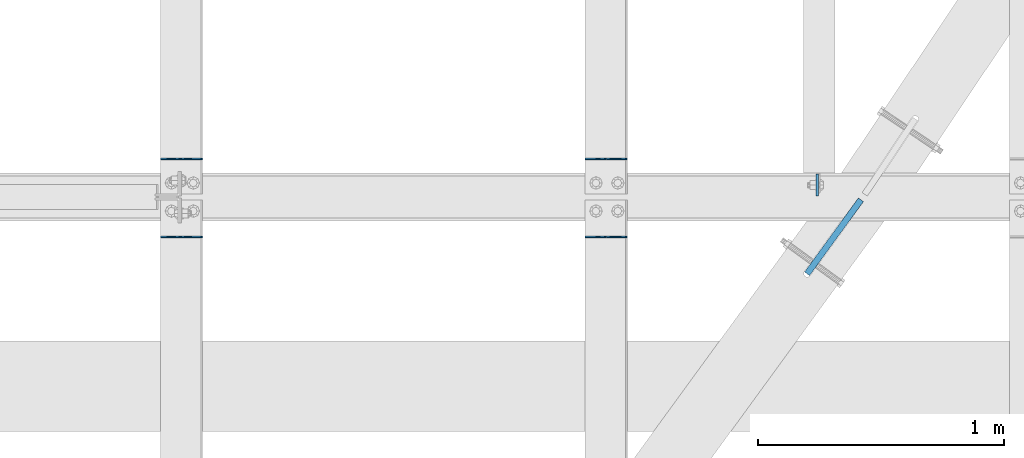
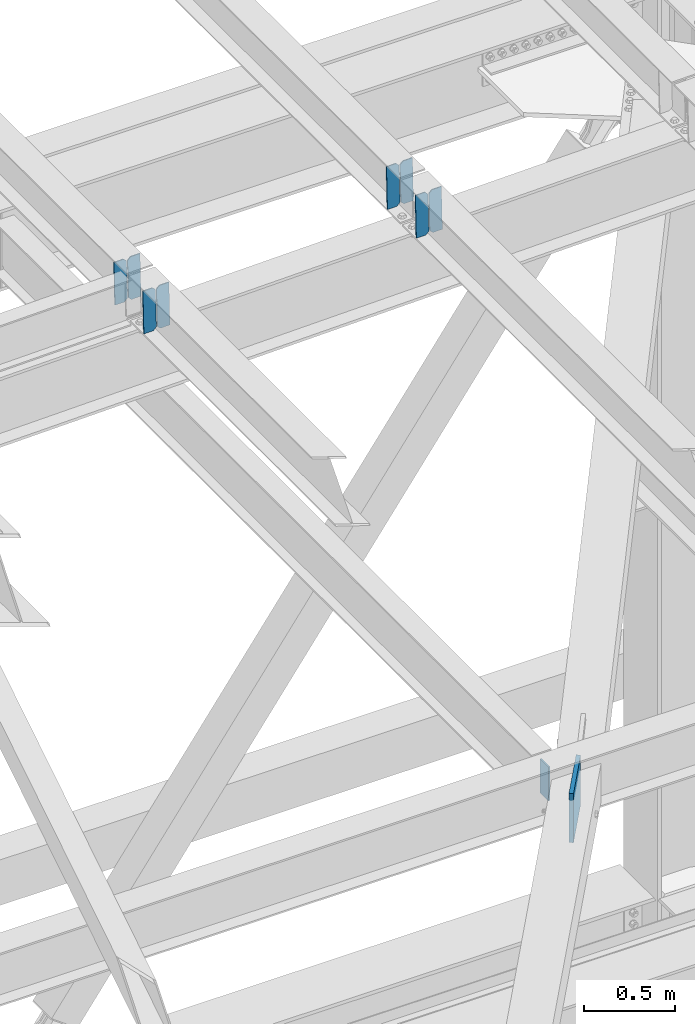
# One storey, part 3636 of 3843: 10 plates, 5 elements without a shape of their own.
"""IFC2X3 building model written with IfcOpenShell, lengths in millimetres."""

from ifc_helpers import new_model, si_unit, frame, origin_with_axes, place, context, subcontext, project, spatial, faceted_brep, material, type_object, element, aggregate, save


model = new_model("IFC2X3")

# Units and contexts
model_context = context("Model", 3, precision=1e-05, world=origin_with_axes())
body_context = subcontext(model_context, "Body", "Model", "MODEL_VIEW")
ifc_project = project(units=[si_unit("LENGTHUNIT", "METRE", prefix="MILLI"), si_unit("AREAUNIT", "SQUARE_METRE"), si_unit("VOLUMEUNIT", "CUBIC_METRE"), si_unit("MASSUNIT", "GRAM", prefix="KILO"), si_unit("TIMEUNIT", "SECOND"), si_unit("PLANEANGLEUNIT", "RADIAN"), si_unit("SOLIDANGLEUNIT", "STERADIAN"), si_unit("THERMODYNAMICTEMPERATUREUNIT", "DEGREE_CELSIUS"), si_unit("LUMINOUSINTENSITYUNIT", "LUMEN")], contexts=[model_context])

# Site, building, storey
site_placement = place(None, origin_with_axes())
site = spatial("IfcSite", under=ifc_project, at=site_placement, CompositionType="ELEMENT")
building_placement = place(site_placement, origin_with_axes())
building = spatial("IfcBuilding", under=site, at=building_placement, Name="Undefined", CompositionType="ELEMENT")
storey_placement = place(building_placement, origin_with_axes())
storey = spatial("IfcBuildingStorey", under=building, at=storey_placement, Name="Undefined", CompositionType="ELEMENT", Elevation=0.0)

# Assembly, plate
assembly_1_placement = place(storey_placement, origin_with_axes())
assembly_1 = element("IfcElementAssembly", 1, at=assembly_1_placement, inside=storey, Name="BEAM", AssemblyPlace="NOTDEFINED", PredefinedType="RIGID_FRAME")
ifc_material = material(Name="STEEL/A572-50")
plate_type_1 = type_object("IfcPlateType", PredefinedType="NOTDEFINED")
plate_1_placement = place(assembly_1_placement, frame((81322.8625, 98390.86875, 42384.6625), z_axis=(0.0, 1.0, 0.0), x_axis=(0.0, 0.0, -1.0)))
plate_1 = element("IfcPlate", 2, at=plate_1_placement, type_object=plate_type_1, material=ifc_material, Name="PLATE", context=body_context, shape_type="Brep", body=[
    faceted_brep([(0.0, -4.76249999999709, 0.0), (0.0, -4.76249999999709, 88.9000015258789), (0.0, 4.76249999999709, 88.9000015258789), (0.0, 4.76249999999709, 0.0), (228.600006102781, -4.7625000004191, 88.9000015257589), (228.600006102781, 4.76249999954598, 88.9000015257443), (228.600006103079, -4.7625000004482, 7.27595761418343e-12), (228.600006103079, 4.76249999954598, -7.27595761418343e-12)], [[[0, 1, 2, 3]], [[1, 4, 5, 2]], [[4, 6, 7, 5]], [[6, 0, 3, 7]], [[5, 7, 3, 2]], [[6, 4, 1, 0]]]),
])

# Assembly, plates
assembly_2_placement = place(storey_placement, origin_with_axes())
assembly_2 = element("IfcElementAssembly", 3, at=assembly_2_placement, inside=storey, Name="BEAM", AssemblyPlace="NOTDEFINED", PredefinedType="RIGID_FRAME")
plate_type_2 = type_object("IfcPlateType", PredefinedType="NOTDEFINED")
plate_2_placement = place(assembly_2_placement, frame((80549.4964784351, 98542.475, 46359.8298575528), z_axis=(-0.0211520980073474, 0.0, 0.999776269347241), x_axis=(-0.999776270257024, 0.0, -0.0211520550054595)))
plate_2 = element("IfcPlate", 4, at=plate_2_placement, type_object=plate_type_2, material=ifc_material, Name="PLATE", context=body_context, shape_type="Brep", body=[
    faceted_brep([(0.0, -3.17499999999927, 0.0), (6.83940015733242e-10, -3.17499999996653, 288.924999998613), (6.54836185276508e-10, 3.17500000001746, 288.924999998591), (0.0, 3.17499999999927, 0.0), (60.3250007643655, -3.17500000017753, 288.924999998606), (60.3250007643219, 3.17499999979918, 288.924999998584), (79.3750000013097, -3.17500000025029, 269.875000761494), (79.375000001266, 3.17499999972642, 269.875000761487), (79.375000000713, -3.17500000026484, 19.0499992370605), (79.3750000006985, 3.17499999971187, 19.0499992370533), (60.325000763667, -3.17500000020664, -1.45519152283669e-11), (60.3250007636234, 3.17499999977736, -3.63797880709171e-11)], [[[0, 1, 2, 3]], [[1, 4, 5, 2]], [[4, 6, 7, 5]], [[6, 8, 9, 7]], [[8, 10, 11, 9]], [[10, 0, 3, 11]], [[5, 7, 9, 11, 3, 2]], [[10, 8, 6, 4, 1, 0]]]),
])
plate_3_placement = place(assembly_2_placement, frame((80463.7906577448, 98542.475, 46358.016593951), z_axis=(-0.0211520980073474, 0.0, 0.999776269347241), x_axis=(-0.999776270257024, 0.0, -0.0211520550054595)))
plate_3 = element("IfcPlate", 5, at=plate_3_placement, type_object=plate_type_2, material=ifc_material, Name="PLATE", context=body_context, shape_type="Brep", body=[
    faceted_brep([(4.36557456851006e-11, -3.17499999998836, 19.0499992370969), (6.11180439591408e-10, -3.17499999996653, 269.875000761516), (5.96628524363041e-10, 3.17500000001746, 269.875000761502), (1.45519152283669e-11, 3.17499999998836, 19.0499992370824), (19.0499992376572, -3.17500000003201, 288.924999998606), (19.0499992376281, 3.1749999999447, 288.924999998584), (79.3750000013242, -3.17500000025029, 288.924999998591), (79.3750000013097, 3.1749999997337, 288.92499999857), (79.3750000006548, -3.17500000026484, -2.18278728425503e-11), (79.3750000006403, 3.17499999969732, -2.91038304567337e-11), (19.0499992370023, -3.17500000005384, 0.0), (19.0499992369587, 3.17499999992287, -1.45519152283669e-11)], [[[0, 1, 2, 3]], [[1, 4, 5, 2]], [[4, 6, 7, 5]], [[6, 8, 9, 7]], [[8, 10, 11, 9]], [[10, 0, 3, 11]], [[5, 7, 9, 11, 3, 2]], [[10, 8, 6, 4, 1, 0]]]),
])
aggregate(assembly_2, [plate_2, plate_3])

assembly_3_placement = place(storey_placement, origin_with_axes())
assembly_3 = element("IfcElementAssembly", 6, at=assembly_3_placement, inside=storey, Name="BEAM", AssemblyPlace="NOTDEFINED", PredefinedType="RIGID_FRAME")
plate_4_placement = place(assembly_3_placement, frame((80549.4964784317, 98224.975, 46359.8298575521), z_axis=(-0.0211520980073474, 0.0, 0.999776269347241), x_axis=(-0.999776270257024, 0.0, -0.0211520550054595)))
plate_4 = element("IfcPlate", 7, at=plate_4_placement, type_object=plate_type_2, material=ifc_material, Name="PLATE", context=body_context, shape_type="Brep", body=[
    faceted_brep([(0.0, -3.17499999999927, 0.0), (6.83940015733242e-10, -3.17499999996653, 288.924999998613), (6.54836185276508e-10, 3.17500000001746, 288.924999998591), (0.0, 3.17499999999927, 0.0), (60.3250007643655, -3.17500000017753, 288.924999998606), (60.3250007643219, 3.17499999979918, 288.924999998584), (79.3750000013097, -3.17500000025029, 269.875000761494), (79.375000001266, 3.17499999972642, 269.875000761487), (79.375000000713, -3.17500000026484, 19.0499992370605), (79.3750000006985, 3.17499999971187, 19.0499992370533), (60.325000763667, -3.17500000020664, -1.45519152283669e-11), (60.3250007636234, 3.17499999977736, -3.63797880709171e-11)], [[[0, 1, 2, 3]], [[1, 4, 5, 2]], [[4, 6, 7, 5]], [[6, 8, 9, 7]], [[8, 10, 11, 9]], [[10, 0, 3, 11]], [[5, 7, 9, 11, 3, 2]], [[10, 8, 6, 4, 1, 0]]]),
])
plate_5_placement = place(assembly_3_placement, frame((80463.7906577414, 98224.975, 46358.0165939504), z_axis=(-0.0211520980073474, 0.0, 0.999776269347241), x_axis=(-0.999776270257024, 0.0, -0.0211520550054595)))
plate_5 = element("IfcPlate", 8, at=plate_5_placement, type_object=plate_type_2, material=ifc_material, Name="PLATE", context=body_context, shape_type="Brep", body=[
    faceted_brep([(4.36557456851006e-11, -3.17499999998836, 19.0499992370969), (6.11180439591408e-10, -3.17499999996653, 269.875000761516), (5.96628524363041e-10, 3.17500000001746, 269.875000761502), (1.45519152283669e-11, 3.17499999998836, 19.0499992370824), (19.0499992376572, -3.17500000003201, 288.924999998606), (19.0499992376281, 3.1749999999447, 288.924999998584), (79.3750000013242, -3.17500000025029, 288.924999998591), (79.3750000013097, 3.1749999997337, 288.92499999857), (79.3750000006548, -3.17500000026484, -2.18278728425503e-11), (79.3750000006403, 3.17499999969732, -2.91038304567337e-11), (19.0499992370023, -3.17500000005384, 0.0), (19.0499992369587, 3.17499999992287, -1.45519152283669e-11)], [[[0, 1, 2, 3]], [[1, 4, 5, 2]], [[4, 6, 7, 5]], [[6, 8, 9, 7]], [[8, 10, 11, 9]], [[10, 0, 3, 11]], [[5, 7, 9, 11, 3, 2]], [[10, 8, 6, 4, 1, 0]]]),
])
aggregate(assembly_3, [plate_4, plate_5])

assembly_4_placement = place(storey_placement, origin_with_axes())
assembly_4 = element("IfcElementAssembly", 9, at=assembly_4_placement, inside=storey, Name="BEAM", AssemblyPlace="NOTDEFINED", PredefinedType="RIGID_FRAME")
plate_6_placement = place(assembly_4_placement, frame((78822.2964784351, 98542.475, 46323.2877782915), z_axis=(-0.0211520980073474, 0.0, 0.999776269347241), x_axis=(-0.999776270257024, 0.0, -0.0211520550054595)))
plate_6 = element("IfcPlate", 10, at=plate_6_placement, type_object=plate_type_2, material=ifc_material, Name="PLATE", context=body_context, shape_type="Brep", body=[
    faceted_brep([(0.0, -3.17499999999927, 0.0), (6.83940015733242e-10, -3.17499999996653, 288.924999998613), (6.54836185276508e-10, 3.17500000001746, 288.924999998591), (0.0, 3.17499999999927, 0.0), (60.3250007643655, -3.17500000017753, 288.924999998606), (60.3250007643219, 3.17499999979918, 288.924999998584), (79.3750000013097, -3.17500000025029, 269.875000761494), (79.375000001266, 3.17499999972642, 269.875000761487), (79.375000000713, -3.17500000026484, 19.0499992370605), (79.3750000006985, 3.17499999971187, 19.0499992370533), (60.325000763667, -3.17500000020664, -1.45519152283669e-11), (60.3250007636234, 3.17499999977736, -3.63797880709171e-11)], [[[0, 1, 2, 3]], [[1, 4, 5, 2]], [[4, 6, 7, 5]], [[6, 8, 9, 7]], [[8, 10, 11, 9]], [[10, 0, 3, 11]], [[5, 7, 9, 11, 3, 2]], [[10, 8, 6, 4, 1, 0]]]),
])
plate_7_placement = place(assembly_4_placement, frame((78736.5906577449, 98542.475, 46321.4745146898), z_axis=(-0.0211520980073474, 0.0, 0.999776269347241), x_axis=(-0.999776270257024, 0.0, -0.0211520550054595)))
plate_7 = element("IfcPlate", 11, at=plate_7_placement, type_object=plate_type_2, material=ifc_material, Name="PLATE", context=body_context, shape_type="Brep", body=[
    faceted_brep([(4.36557456851006e-11, -3.17499999998836, 19.0499992370969), (6.11180439591408e-10, -3.17499999996653, 269.875000761516), (5.96628524363041e-10, 3.17500000001746, 269.875000761502), (1.45519152283669e-11, 3.17499999998836, 19.0499992370824), (19.0499992376572, -3.17500000003201, 288.924999998606), (19.0499992376281, 3.1749999999447, 288.924999998584), (79.3750000013242, -3.17500000025029, 288.924999998591), (79.3750000013097, 3.1749999997337, 288.92499999857), (79.3750000006548, -3.17500000026484, -2.18278728425503e-11), (79.3750000006403, 3.17499999969732, -2.91038304567337e-11), (19.0499992370023, -3.17500000005384, 0.0), (19.0499992369587, 3.17499999992287, -1.45519152283669e-11)], [[[0, 1, 2, 3]], [[1, 4, 5, 2]], [[4, 6, 7, 5]], [[6, 8, 9, 7]], [[8, 10, 11, 9]], [[10, 0, 3, 11]], [[5, 7, 9, 11, 3, 2]], [[10, 8, 6, 4, 1, 0]]]),
])
aggregate(assembly_4, [plate_6, plate_7])

assembly_5_placement = place(storey_placement, origin_with_axes())
assembly_5 = element("IfcElementAssembly", 12, at=assembly_5_placement, inside=storey, Name="BEAM", AssemblyPlace="NOTDEFINED", PredefinedType="RIGID_FRAME")
plate_8_placement = place(assembly_5_placement, frame((78822.2964784317, 98224.975, 46323.2877782908), z_axis=(-0.0211520980073474, 0.0, 0.999776269347241), x_axis=(-0.999776270257024, 0.0, -0.0211520550054595)))
plate_8 = element("IfcPlate", 13, at=plate_8_placement, type_object=plate_type_2, material=ifc_material, Name="PLATE", context=body_context, shape_type="Brep", body=[
    faceted_brep([(0.0, -3.17499999999927, 0.0), (6.83940015733242e-10, -3.17499999996653, 288.924999998613), (6.54836185276508e-10, 3.17500000001746, 288.924999998591), (0.0, 3.17499999999927, 0.0), (60.3250007643655, -3.17500000017753, 288.924999998606), (60.3250007643219, 3.17499999979918, 288.924999998584), (79.3750000013097, -3.17500000025029, 269.875000761494), (79.375000001266, 3.17499999972642, 269.875000761487), (79.375000000713, -3.17500000026484, 19.0499992370605), (79.3750000006985, 3.17499999971187, 19.0499992370533), (60.325000763667, -3.17500000020664, -1.45519152283669e-11), (60.3250007636234, 3.17499999977736, -3.63797880709171e-11)], [[[0, 1, 2, 3]], [[1, 4, 5, 2]], [[4, 6, 7, 5]], [[6, 8, 9, 7]], [[8, 10, 11, 9]], [[10, 0, 3, 11]], [[5, 7, 9, 11, 3, 2]], [[10, 8, 6, 4, 1, 0]]]),
])
plate_9_placement = place(assembly_5_placement, frame((78736.5906577414, 98224.975, 46321.4745146891), z_axis=(-0.0211520980073474, 0.0, 0.999776269347241), x_axis=(-0.999776270257024, 0.0, -0.0211520550054595)))
plate_9 = element("IfcPlate", 14, at=plate_9_placement, type_object=plate_type_2, material=ifc_material, Name="PLATE", context=body_context, shape_type="Brep", body=[
    faceted_brep([(4.36557456851006e-11, -3.17499999998836, 19.0499992370969), (6.11180439591408e-10, -3.17499999996653, 269.875000761516), (5.96628524363041e-10, 3.17500000001746, 269.875000761502), (1.45519152283669e-11, 3.17499999998836, 19.0499992370824), (19.0499992376572, -3.17500000003201, 288.924999998606), (19.0499992376281, 3.1749999999447, 288.924999998584), (79.3750000013242, -3.17500000025029, 288.924999998591), (79.3750000013097, 3.1749999997337, 288.92499999857), (79.3750000006548, -3.17500000026484, -2.18278728425503e-11), (79.3750000006403, 3.17499999969732, -2.91038304567337e-11), (19.0499992370023, -3.17500000005384, 0.0), (19.0499992369587, 3.17499999992287, -1.45519152283669e-11)], [[[0, 1, 2, 3]], [[1, 4, 5, 2]], [[4, 6, 7, 5]], [[6, 8, 9, 7]], [[8, 10, 11, 9]], [[10, 0, 3, 11]], [[5, 7, 9, 11, 3, 2]], [[10, 8, 6, 4, 1, 0]]]),
])
aggregate(assembly_5, [plate_8, plate_9])

# Plate
plate_type_3 = type_object("IfcPlateType", PredefinedType="NOTDEFINED")
plate_10_placement = place(assembly_1_placement, frame((81500.2630398735, 98375.4539011627, 42081.45), z_axis=(0.0, 0.0, 1.0), x_axis=(-0.588764889304563, -0.808304339418134, 0.0)))
plate_10 = element("IfcPlate", 15, at=plate_10_placement, type_object=plate_type_3, material=ifc_material, Name="STIFFENER", context=body_context, shape_type="Brep", body=[
    faceted_brep([(4.10364009439945e-09, -12.700000000008, 22.2250003814697), (0.0, -12.6999999999825, 330.199999999997), (-1.45519152283669e-11, 12.699999999968, 330.199999999997), (-2.3032567586398e-12, 12.700000002973, 22.2250003814697), (372.01356860096, -12.7000000028384, 330.199999953002), (372.013568601149, 12.6999999971849, 330.199999953002), (372.013568490162, -12.7000000028384, -2.88855517283082e-09), (372.013568490365, 12.6999999971922, -2.88855517283082e-09), (22.2250003813824, -12.7000000001754, -1.74622982740402e-10), (22.2250003814697, 12.700000002973, 0.0)], [[[0, 1, 2, 3]], [[1, 4, 5, 2]], [[4, 6, 7, 5]], [[6, 8, 9, 7]], [[8, 0, 3, 9]], [[5, 7, 9, 3, 2]], [[8, 6, 4, 1, 0]]]),
])

aggregate(assembly_1, [plate_10, plate_1])

save(model, "model.ifc")
